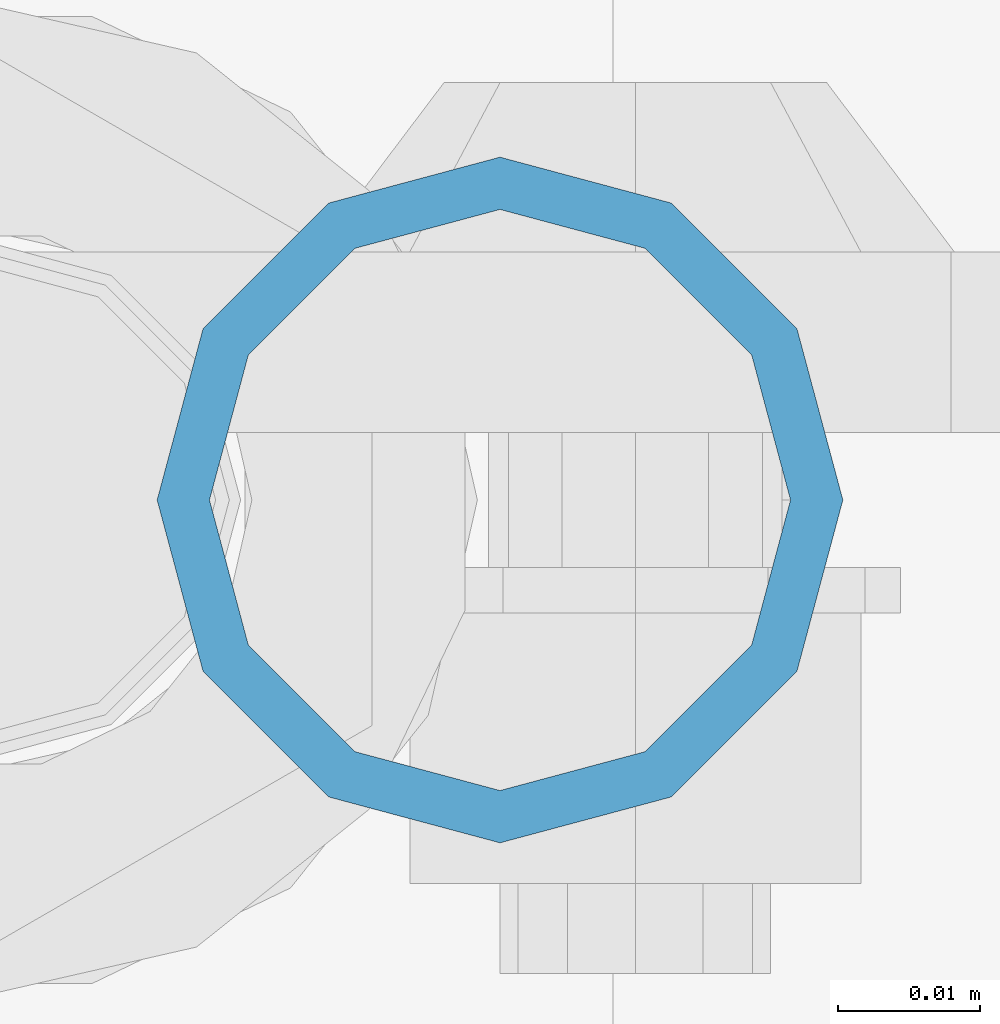
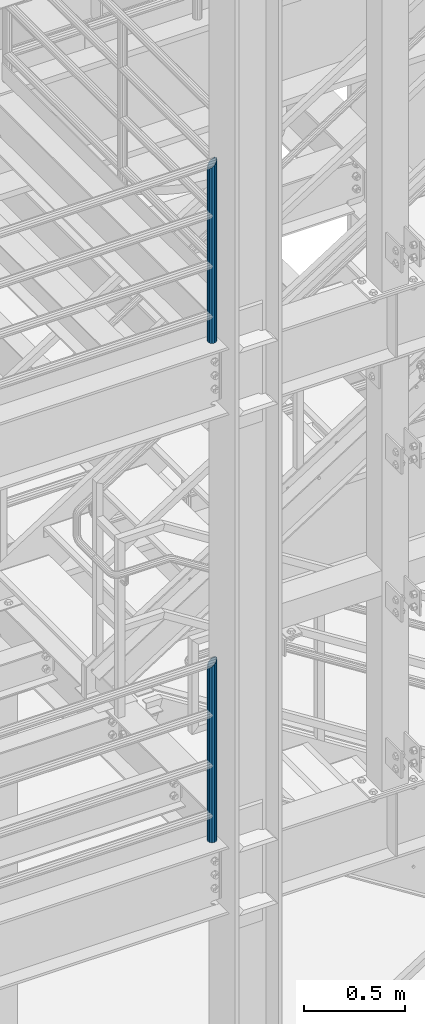
# One storey, part 560 of 1876: 2 columns, 2 elements without a shape of their own.
"""IFC2X3 building model written with IfcOpenShell, lengths in millimetres."""

from ifc_helpers import new_model, si_unit, frame, origin_with_axes, place, context, subcontext, project, spatial, faceted_brep, material, type_object, element, aggregate, save


model = new_model("IFC2X3")

# Units and contexts
model_context = context("Model", 3, precision=1e-05, world=origin_with_axes())
body_context = subcontext(model_context, "Body", "Model", "MODEL_VIEW")
ifc_project = project(units=[si_unit("LENGTHUNIT", "METRE", prefix="MILLI"), si_unit("AREAUNIT", "SQUARE_METRE"), si_unit("VOLUMEUNIT", "CUBIC_METRE"), si_unit("MASSUNIT", "GRAM", prefix="KILO"), si_unit("TIMEUNIT", "SECOND"), si_unit("PLANEANGLEUNIT", "RADIAN"), si_unit("SOLIDANGLEUNIT", "STERADIAN"), si_unit("THERMODYNAMICTEMPERATUREUNIT", "DEGREE_CELSIUS"), si_unit("LUMINOUSINTENSITYUNIT", "LUMEN")], contexts=[model_context])

# Site, building, storey
site_placement = place(None, origin_with_axes())
site = spatial("IfcSite", under=ifc_project, at=site_placement, CompositionType="ELEMENT")
building_placement = place(site_placement, origin_with_axes())
building = spatial("IfcBuilding", under=site, at=building_placement, Name="Undefined", CompositionType="ELEMENT")
storey_placement = place(building_placement, origin_with_axes())
storey = spatial("IfcBuildingStorey", under=building, at=storey_placement, Name="Undefined", CompositionType="ELEMENT", Elevation=0.0)

# Assembly, column
assembly_1_placement = place(storey_placement, origin_with_axes())
assembly_1 = element("IfcElementAssembly", 1, at=assembly_1_placement, inside=storey, Name="RAIL", AssemblyPlace="NOTDEFINED", PredefinedType="RIGID_FRAME")
ifc_material = material()
column_type = type_object("IfcColumnType", Name="PIPE1-1/2SCH40", PredefinedType="NOTDEFINED")
column_1_placement = place(assembly_1_placement, frame((1535.1125, -7112.0, 5130.8), z_axis=(0.0, 1.0, 0.0), x_axis=(0.0, 0.0, 1.0)))
column_1 = element("IfcColumn", 2, at=column_1_placement, type_object=column_type, material=ifc_material, Name="POST", ObjectType="PIPE1-1/2SCH40", context=body_context, shape_type="Brep", body=[
    faceted_brep([(0.0, -20.4469999999999, 0.0), (0.0, -17.7076214311803, 10.2235000000001), (1058.61737856882, -17.7076214311803, 10.2235000000001), (1055.878, -20.4469999999999, 0.0), (0.0, -10.2235000000001, 17.7076214311801), (1066.1015, -10.2235000000001, 17.7076214311801), (-1.45519152283669e-11, 0.0, 20.4470000000001), (1076.325, 0.0, 20.4470000000001), (0.0, 10.2235000000001, 17.7076214311801), (1086.5485, 10.2235000000001, 17.7076214311801), (0.0, 17.7076214311803, 10.2235000000001), (1094.03262143118, 17.7076214311803, 10.2235000000001), (0.0, 20.4469999999999, 0.0), (1096.772, 20.4469999999999, 0.0), (0.0, 17.7076214311803, -10.2235000000001), (1094.03262143118, 17.7076214311803, -10.2235000000001), (0.0, 10.2235000000001, -17.7076214311801), (1086.5485, 10.2235000000001, -17.7076214311801), (-1.45519152283669e-11, 0.0, -20.4470000000001), (1076.325, 0.0, -20.4470000000001), (0.0, -10.2235000000001, -17.7076214311801), (1066.1015, -10.2235000000001, -17.7076214311801), (0.0, -17.7076214311803, -10.2235000000001), (1058.61737856882, -17.7076214311803, -10.2235000000001), (0.0, -24.1299999999992, 0.0), (0.0, -20.8971929933184, -12.0649999999996), (1055.42780700668, -20.8971929933184, -12.0649999999996), (1052.195, -24.1300000000001, 0.0), (0.0, -12.0650000000001, -20.8971929933186), (1064.26, -12.0650000000001, -20.8971929933186), (-1.45519152283669e-11, 0.0, -24.130000000001), (1076.325, 0.0, -24.1300000000001), (0.0, 12.0650000000001, -20.8971929933186), (1088.39, 12.0650000000001, -20.8971929933186), (0.0, 20.8971929933184, -12.0649999999996), (1097.22219299332, 20.8971929933184, -12.0649999999996), (0.0, 24.1299999999992, 0.0), (1100.455, 24.1300000000001, 0.0), (0.0, 20.8971929933184, 12.0649999999996), (1097.22219299332, 20.8971929933184, 12.0649999999996), (0.0, 12.0650000000001, 20.8971929933186), (1088.39, 12.0650000000001, 20.8971929933186), (-1.45519152283669e-11, 0.0, 24.130000000001), (1076.325, 0.0, 24.1300000000001), (0.0, -12.0650000000001, 20.8971929933186), (1064.26, -12.0650000000001, 20.8971929933186), (0.0, -20.8971929933184, 12.0649999999996), (1055.42780700668, -20.8971929933184, 12.0649999999996)], [[[0, 1, 2, 3]], [[1, 4, 5, 2]], [[4, 6, 7, 5]], [[6, 8, 9, 7]], [[8, 10, 11, 9]], [[10, 12, 13, 11]], [[12, 14, 15, 13]], [[14, 16, 17, 15]], [[16, 18, 19, 17]], [[18, 20, 21, 19]], [[20, 22, 23, 21]], [[22, 0, 3, 23]], [[24, 25, 26, 27]], [[25, 28, 29, 26]], [[28, 30, 31, 29]], [[30, 32, 33, 31]], [[32, 34, 35, 33]], [[34, 36, 37, 35]], [[36, 38, 39, 37]], [[38, 40, 41, 39]], [[40, 42, 43, 41]], [[42, 44, 45, 43]], [[44, 46, 47, 45]], [[46, 24, 27, 47]], [[29, 31, 33, 35, 37, 39, 41, 43, 45, 47, 27, 26], [5, 7, 9, 11, 13, 15, 17, 19, 21, 23, 3, 2]], [[46, 44, 42, 40, 38, 36, 34, 32, 30, 28, 25, 24], [22, 20, 18, 16, 14, 12, 10, 8, 6, 4, 1, 0]]]),
])
aggregate(assembly_1, [column_1])

assembly_2_placement = place(storey_placement, origin_with_axes())
assembly_2 = element("IfcElementAssembly", 3, at=assembly_2_placement, inside=storey, Name="RAIL", AssemblyPlace="NOTDEFINED", PredefinedType="RIGID_FRAME")
column_2_placement = place(assembly_2_placement, frame((1535.1125, -7112.0, 8153.4), z_axis=(0.0, 1.0, 0.0), x_axis=(0.0, 0.0, 1.0)))
column_2 = element("IfcColumn", 4, at=column_2_placement, type_object=column_type, material=ifc_material, Name="POST", ObjectType="PIPE1-1/2SCH40", context=body_context, shape_type="Brep", body=[
    faceted_brep([(0.0, -20.4469999999999, 0.0), (0.0, -17.7076214311803, 10.2235000000001), (1058.61737856882, -17.7076214311803, 10.2235000000001), (1055.878, -20.4469999999999, 0.0), (0.0, -10.2235000000001, 17.7076214311801), (1066.1015, -10.2235000000001, 17.7076214311801), (-1.45519152283669e-11, 0.0, 20.4470000000001), (1076.325, 0.0, 20.4470000000001), (0.0, 10.2235000000001, 17.7076214311801), (1086.5485, 10.2235000000001, 17.7076214311801), (0.0, 17.7076214311803, 10.2235000000001), (1094.03262143118, 17.7076214311803, 10.2235000000001), (0.0, 20.4469999999999, 0.0), (1096.772, 20.4469999999999, 0.0), (0.0, 17.7076214311803, -10.2235000000001), (1094.03262143118, 17.7076214311803, -10.2235000000001), (0.0, 10.2235000000001, -17.7076214311801), (1086.5485, 10.2235000000001, -17.7076214311801), (-1.45519152283669e-11, 0.0, -20.4470000000001), (1076.325, 0.0, -20.4470000000001), (0.0, -10.2235000000001, -17.7076214311801), (1066.1015, -10.2235000000001, -17.7076214311801), (0.0, -17.7076214311803, -10.2235000000001), (1058.61737856882, -17.7076214311803, -10.2235000000001), (0.0, -24.1299999999992, 0.0), (0.0, -20.8971929933184, -12.0649999999996), (1055.42780700668, -20.8971929933184, -12.0649999999996), (1052.195, -24.1300000000001, 0.0), (0.0, -12.0650000000001, -20.8971929933186), (1064.26, -12.0650000000001, -20.8971929933186), (-1.45519152283669e-11, 0.0, -24.130000000001), (1076.325, 0.0, -24.1300000000001), (0.0, 12.0650000000001, -20.8971929933186), (1088.39, 12.0650000000001, -20.8971929933186), (0.0, 20.8971929933184, -12.0649999999996), (1097.22219299332, 20.8971929933184, -12.0649999999996), (0.0, 24.1299999999992, 0.0), (1100.455, 24.1300000000001, 0.0), (0.0, 20.8971929933184, 12.0649999999996), (1097.22219299332, 20.8971929933184, 12.0649999999996), (0.0, 12.0650000000001, 20.8971929933186), (1088.39, 12.0650000000001, 20.8971929933186), (-1.45519152283669e-11, 0.0, 24.130000000001), (1076.325, 0.0, 24.1300000000001), (0.0, -12.0650000000001, 20.8971929933186), (1064.26, -12.0650000000001, 20.8971929933186), (0.0, -20.8971929933184, 12.0649999999996), (1055.42780700668, -20.8971929933184, 12.0649999999996)], [[[0, 1, 2, 3]], [[1, 4, 5, 2]], [[4, 6, 7, 5]], [[6, 8, 9, 7]], [[8, 10, 11, 9]], [[10, 12, 13, 11]], [[12, 14, 15, 13]], [[14, 16, 17, 15]], [[16, 18, 19, 17]], [[18, 20, 21, 19]], [[20, 22, 23, 21]], [[22, 0, 3, 23]], [[24, 25, 26, 27]], [[25, 28, 29, 26]], [[28, 30, 31, 29]], [[30, 32, 33, 31]], [[32, 34, 35, 33]], [[34, 36, 37, 35]], [[36, 38, 39, 37]], [[38, 40, 41, 39]], [[40, 42, 43, 41]], [[42, 44, 45, 43]], [[44, 46, 47, 45]], [[46, 24, 27, 47]], [[29, 31, 33, 35, 37, 39, 41, 43, 45, 47, 27, 26], [5, 7, 9, 11, 13, 15, 17, 19, 21, 23, 3, 2]], [[46, 44, 42, 40, 38, 36, 34, 32, 30, 28, 25, 24], [22, 20, 18, 16, 14, 12, 10, 8, 6, 4, 1, 0]]]),
])
aggregate(assembly_2, [column_2])

save(model, "model.ifc")
